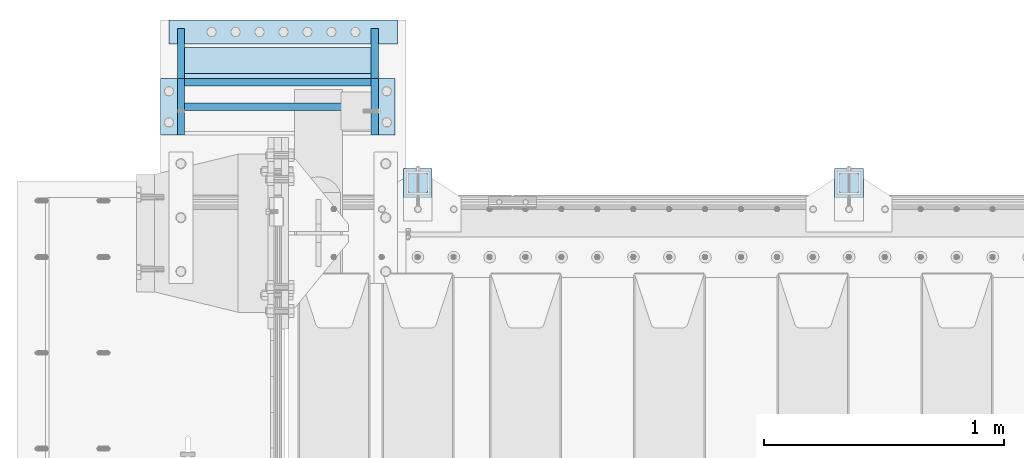
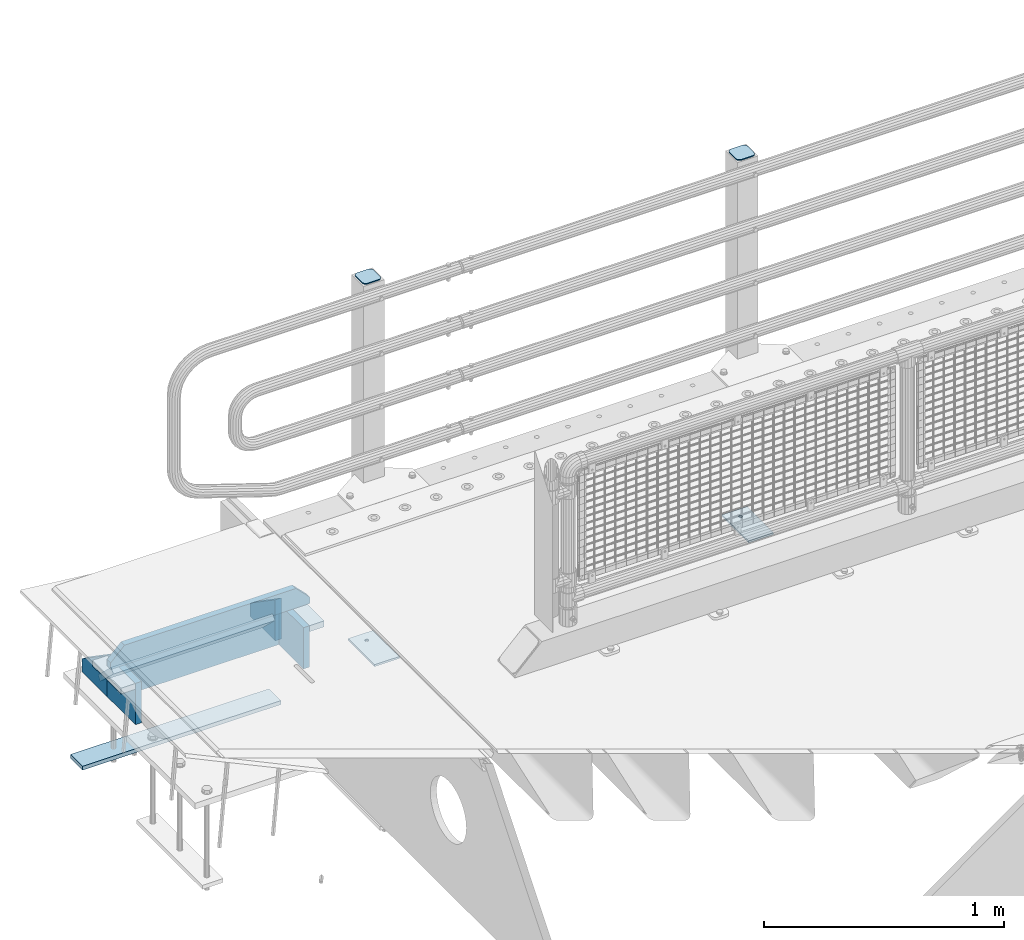
# One storey, part 231 of 270: 14 plates.
"""IFC2X3 building model written with IfcOpenShell, lengths in millimetres."""

from ifc_helpers import new_model, si_unit, frame, origin_with_axes, place, context, subcontext, project, spatial, faceted_brep, material, type_object, element, save


model = new_model("IFC2X3")

# Units and contexts
model_context = context("Model", 3, precision=1e-05, world=origin_with_axes())
body_context = subcontext(model_context, "Body", "Model", "MODEL_VIEW")
ifc_project = project(units=[si_unit("LENGTHUNIT", "METRE", prefix="MILLI"), si_unit("AREAUNIT", "SQUARE_METRE"), si_unit("VOLUMEUNIT", "CUBIC_METRE"), si_unit("MASSUNIT", "GRAM", prefix="KILO"), si_unit("TIMEUNIT", "SECOND"), si_unit("PLANEANGLEUNIT", "RADIAN"), si_unit("SOLIDANGLEUNIT", "STERADIAN"), si_unit("THERMODYNAMICTEMPERATUREUNIT", "DEGREE_CELSIUS"), si_unit("LUMINOUSINTENSITYUNIT", "LUMEN")], contexts=[model_context])

# Site, building, storey
site_placement = place(None, origin_with_axes())
site = spatial("IfcSite", under=ifc_project, at=site_placement, CompositionType="ELEMENT")
building_placement = place(site_placement, origin_with_axes())
building = spatial("IfcBuilding", under=site, at=building_placement, Name="Standard", CompositionType="ELEMENT")
storey_placement = place(building_placement, origin_with_axes())
storey = spatial("IfcBuildingStorey", under=building, at=storey_placement, Name="Undefined", CompositionType="ELEMENT", Elevation=0.0)

# Plates
ifc_material_1 = material(Name="STEEL/S355N")
plate_type_1 = type_object("IfcPlateType", PredefinedType="NOTDEFINED")
plate_1_placement = place(storey_placement, frame((354.999999574469, -14234.6428636522, -1027.14966545659), z_axis=(-1.0, 0.0, 0.0), x_axis=(9.99999918650255e-10, -0.723355636225728, 0.690475650215467)))
element("IfcPlate", 1, at=plate_1_placement, inside=storey, type_object=plate_type_1, material=ifc_material_1, context=body_context, shape_type="Brep", body=[
    faceted_brep([(0.0, -15.0, 0.0), (2.15506588574499e-07, -15.0000000000018, 779.0), (2.15506588574499e-07, 14.9999999999982, 779.0), (0.0, 15.0, 0.0), (152.069061494802, -15.0000000000018, 779.0), (152.069061494802, 14.9999999999982, 779.0), (152.069061279297, -15.0000000000018, 0.0), (152.069061279299, 14.9999999999964, 0.0)], [[[0, 1, 2, 3]], [[1, 4, 5, 2]], [[4, 6, 7, 5]], [[6, 0, 3, 7]], [[5, 7, 3, 2]], [[6, 4, 1, 0]]]),
])
plate_type_2 = type_object("IfcPlateType", PredefinedType="NOTDEFINED")
plate_2_placement = place(storey_placement, frame((-489.000000550228, -14110.0000007156, -1478.0), z_axis=(0.0, -1.0, 0.0), x_axis=(1.0, 0.0, 0.0)))
element("IfcPlate", 2, at=plate_2_placement, inside=storey, type_object=plate_type_2, material=ifc_material_1, context=body_context, shape_type="Brep", body=[
    faceted_brep([(0.0, -10.0, 0.0), (0.0, -10.0, 100.0), (0.0, 10.0, 100.0), (0.0, 10.0, 0.0), (955.0, -10.0, 100.0), (955.0, 10.0, 100.0), (955.0, -10.0, 0.0), (955.0, 10.0, 0.0)], [[[0, 1, 2, 3]], [[1, 4, 5, 2]], [[4, 6, 7, 5]], [[6, 0, 3, 7]], [[5, 7, 3, 2]], [[6, 4, 1, 0]]]),
])
plate_type_3 = type_object("IfcPlateType", PredefinedType="NOTDEFINED")
for number, where, z_axis, x_axis in (
    (3, (369.999999484789, -14144.9999983904, -1038.0), (0.0, 0.0, 1.0), (0.0, -1.0, 0.0)),
    (4, (-439.000000515214, -14144.9999991994, -1038.0), (0.0, 0.0, 1.0), (0.0, -1.0, 0.0)),
):
    element("IfcPlate", number, at=place(storey_placement, frame(where, z_axis=z_axis, x_axis=x_axis)), inside=storey, type_object=plate_type_3, material=ifc_material_1, context=body_context, shape_type="Brep", body=[
        faceted_brep([(0.0, -15.0, 0.0), (-1.81898940354586e-12, -15.0, 66.0), (0.0, 15.0, 66.0), (0.0, 15.0, 0.0), (209.999999999998, -15.0, 210.0), (210.0, 15.0, 210.0), (209.999999999998, -15.0, 0.0), (210.0, 15.0, 0.0)], [[[0, 1, 2, 3]], [[1, 4, 5, 2]], [[4, 6, 7, 5]], [[6, 0, 3, 7]], [[5, 7, 3, 2]], [[6, 4, 1, 0]]]),
    ])
plate_3_placement = place(storey_placement, frame((369.999999929987, -14589.9999983904, -828.000000000005), z_axis=(0.0, 0.0, -1.0), x_axis=(0.0, 1.0, 0.0)))
element("IfcPlate", 5, at=plate_3_placement, inside=storey, type_object=plate_type_3, material=ifc_material_1, context=body_context, shape_type="Brep", body=[
    faceted_brep([(0.0, -15.0, 0.0), (1.81898940354586e-12, -15.0, 210.0), (0.0, 15.0, 210.0), (0.0, 15.0, 0.0), (235.000000000002, -15.0, 210.0), (235.0, 15.0, 210.0), (235.0, -15.0, 0.0), (235.0, 15.0, 0.0)], [[[0, 1, 2, 3]], [[1, 4, 5, 2]], [[4, 6, 7, 5]], [[6, 0, 3, 7]], [[5, 7, 3, 2]], [[6, 4, 1, 0]]]),
])
plate_4_placement = place(storey_placement, frame((-424.000000290111, -14369.9999991844, -1038.0), z_axis=(1.0, 0.0, 0.0), x_axis=(0.0, 0.0, 1.0)))
element("IfcPlate", 6, at=plate_4_placement, inside=storey, type_object=plate_type_3, material=ifc_material_1, context=body_context, shape_type="Brep", body=[
    faceted_brep([(0.0, -15.0, 0.0), (2.15506588574499e-07, -15.0000000000018, 779.0), (2.15506588574499e-07, 14.9999999999982, 779.0), (0.0, 15.0, 0.0), (210.0, -15.0, 779.0), (210.0, 15.0, 779.0), (209.999999999998, -15.0, 0.0), (210.0, 15.0, 0.0)], [[[0, 1, 2, 3]], [[1, 4, 5, 2]], [[4, 6, 7, 5]], [[6, 0, 3, 7]], [[5, 7, 3, 2]], [[6, 4, 1, 0]]]),
])
plate_5_placement = place(storey_placement, frame((-439.000000070013, -14589.9999991994, -828.000000000004), z_axis=(0.0, 0.0, -1.0), x_axis=(0.0, 1.0, 0.0)))
element("IfcPlate", 7, at=plate_5_placement, inside=storey, type_object=plate_type_3, material=ifc_material_1, context=body_context, shape_type="Brep", body=[
    faceted_brep([(0.0, -15.0, 0.0), (1.81898940354586e-12, -15.0, 210.0), (0.0, 15.0, 210.0), (0.0, 15.0, 0.0), (235.000000000002, -15.0, 210.0), (235.0, 15.0, 210.0), (235.0, -15.0, 0.0), (235.0, 15.0, 0.0)], [[[0, 1, 2, 3]], [[1, 4, 5, 2]], [[4, 6, 7, 5]], [[6, 0, 3, 7]], [[5, 7, 3, 2]], [[6, 4, 1, 0]]]),
])
plate_type_4 = type_object("IfcPlateType", PredefinedType="NOTDEFINED")
plate_6_placement = place(storey_placement, frame((-514.000000187565, -14472.4999992744, -798.000000000004), z_axis=(0.0, 0.0, 1.0), x_axis=(1.0, 0.0, 0.0)))
element("IfcPlate", 8, at=plate_6_placement, inside=storey, type_object=plate_type_4, material=ifc_material_1, context=body_context, shape_type="Brep", body=[
    faceted_brep([(0.0, -15.0, 0.0), (-1.13686837721616e-13, -15.0, 33.0), (0.0, 15.0, 33.0), (0.0, 15.0, 0.0), (66.9999999999999, -15.0, 100.0), (66.9999999999999, 15.0, 100.0), (892.0, -15.0000000000018, 100.0), (892.0, 14.9999999999982, 100.0), (959.0, -15.0, 33.0), (959.0, 15.0, 33.0), (959.0, -15.0, 0.0), (959.0, 15.0, 0.0)], [[[0, 1, 2, 3]], [[1, 4, 5, 2]], [[4, 6, 7, 5]], [[6, 8, 9, 7]], [[8, 10, 11, 9]], [[10, 0, 3, 11]], [[5, 7, 9, 11, 3, 2]], [[10, 8, 6, 4, 1, 0]]]),
])
plate_type_5 = type_object("IfcPlateType", PredefinedType="NOTDEFINED")
for number, where, z_axis, x_axis in (
    (9, (384.999999694883, -14354.9999983754, -843.000000000004), (1.0, 0.0, 0.0), (0.0, -1.0, 0.0)),
    (10, (-524.000000305117, -14354.9999992844, -843.000000000004), (1.0, 0.0, 0.0), (0.0, -1.0, 0.0)),
):
    element("IfcPlate", number, at=place(storey_placement, frame(where, z_axis=z_axis, x_axis=x_axis)), inside=storey, type_object=plate_type_5, material=ifc_material_1, context=body_context, shape_type="Brep", body=[
        faceted_brep([(0.0, -15.0, 0.0), (0.0, -15.0, 70.0), (0.0, 15.0, 70.0), (0.0, 15.0, 0.0), (235.0, -15.0, 70.0), (235.0, 15.0, 70.0), (235.0, -15.0, 0.0), (235.0, 15.0, 0.0)], [[[0, 1, 2, 3]], [[1, 4, 5, 2]], [[4, 6, 7, 5]], [[6, 0, 3, 7]], [[5, 7, 3, 2]], [[6, 4, 1, 0]]]),
    ])
ifc_material_2 = material(Name="STEEL/S355J2")
plate_type_6 = type_object("IfcPlateType", PredefinedType="NOTDEFINED")
for number, where, z_axis, x_axis in (
    (11, (2290.00000000014, -14949.9999999998, -850.000000000002), (0.0, 1.0, 0.0), (1.0, 0.0, 0.0)),
    (12, (490.000000000138, -14949.9999999998, -850.000000000002), (0.0, 1.0, 0.0), (1.0, 0.0, 0.0)),
):
    element("IfcPlate", number, at=place(storey_placement, frame(where, z_axis=z_axis, x_axis=x_axis)), inside=storey, type_object=plate_type_6, material=ifc_material_2, context=body_context, shape_type="Brep", body=[
        faceted_brep([(66.3639610305399, -5.0, 163.636038969114), (66.3639610305399, 5.0, 163.636038969114), (59.9999999998618, 5.0, 160.999999999793), (59.9999999998618, -5.0, 160.999999999793), (53.6360389691836, 5.0, 163.636038969114), (53.6360389691836, -5.0, 163.636038969114), (50.9999999998618, 5.0, 169.999999999793), (50.9999999998618, -5.0, 169.999999999793), (53.6360389691836, 5.0, 176.363961030471), (53.6360389691836, -5.0, 176.363961030471), (59.9999999998618, 5.0, 178.999999999793), (59.9999999998618, -5.0, 178.999999999793), (66.3639610305399, 5.0, 176.363961030471), (66.3639610305399, -5.0, 176.363961030471), (68.9999999998618, 5.0, 169.999999999793), (68.9999999998618, -5.0, 169.999999999793), (120.0, -5.0, 0.0), (120.0, -5.0, 220.0), (0.0, -5.0, 220.0), (0.0, -5.0, 0.0), (0.0, 5.0, 0.0), (120.0, 5.0, 0.0), (120.0, 5.0, 220.0), (0.0, 5.0, 220.0)], [[[0, 1, 2, 3]], [[3, 2, 4, 5]], [[5, 4, 6, 7]], [[7, 6, 8, 9]], [[9, 8, 10, 11]], [[11, 10, 12, 13]], [[13, 12, 14, 15]], [[15, 14, 1, 0]], [[16, 17, 18, 19], [3, 5, 7, 9, 11, 13, 15, 0]], [[16, 19, 20, 21]], [[17, 16, 21, 22]], [[18, 17, 22, 23]], [[19, 18, 23, 20]], [[22, 21, 20, 23], [10, 8, 6, 4, 2, 1, 14, 12]]]),
    ])
plate_type_7 = type_object("IfcPlateType", PredefinedType="NOTDEFINED")
plate_7_placement = place(storey_placement, frame((2394.00000000013, -14833.9999999998, 1012.50000000001), z_axis=(0.0, 1.0, 0.0), x_axis=(-1.0, 0.0, 0.0)))
element("IfcPlate", 13, at=plate_7_placement, inside=storey, type_object=plate_type_7, material=ifc_material_2, context=body_context, shape_type="Brep", body=[
    faceted_brep([(0.0, -2.5, 19.0), (0.0, -2.5, 69.0), (0.0, 2.5, 69.0), (0.0, 2.5, 19.0), (0.476369668544066, -2.5, 73.2278977451697), (0.476369668544066, 2.5, 73.2278977451697), (1.88159150985302, -2.5, 77.2437910432327), (1.88159150985302, 2.5, 77.2437910432327), (4.14520183310742, -2.5, 80.8463062353167), (4.14520183310742, 2.5, 80.8463062353167), (7.15369376468516, -2.5, 83.8547981668926), (7.15369376468516, 2.5, 83.8547981668926), (10.7562089567655, -2.5, 86.1184084901452), (10.7562089567655, 2.5, 86.1184084901452), (14.7721022548285, -2.5, 87.5236303314541), (14.7721022548285, 2.5, 87.5236303314541), (19.0, -2.5, 88.0), (19.0, 2.5, 88.0), (69.0, -2.5, 88.0), (69.0, 2.5, 88.0), (73.2278977451715, -2.5, 87.5236303314541), (73.2278977451715, 2.5, 87.5236303314541), (77.2437910432345, -2.5, 86.1184084901452), (77.2437910432345, 2.5, 86.1184084901452), (80.8463062353148, -2.5, 83.8547981668926), (80.8463062353148, 2.5, 83.8547981668926), (83.8547981668926, -2.5, 80.8463062353167), (83.8547981668926, 2.5, 80.8463062353167), (86.118408490147, -2.5, 77.2437910432345), (86.118408490147, 2.5, 77.2437910432345), (87.5236303314559, -2.5, 73.2278977451697), (87.5236303314559, 2.5, 73.2278977451697), (88.0, -2.5, 69.0), (88.0, 2.5, 69.0), (88.0, -2.5, 19.0), (88.0, 2.5, 19.0), (87.5236303314559, -2.5, 14.7721022548303), (87.5236303314559, 2.5, 14.7721022548303), (86.118408490147, -2.5, 10.7562089567673), (86.118408490147, 2.5, 10.7562089567673), (83.8547981668926, -2.5, 7.15369376468334), (83.8547981668926, 2.5, 7.15369376468334), (80.8463062353148, -2.5, 4.14520183310742), (80.8463062353148, 2.5, 4.14520183310742), (77.2437910432345, -2.5, 1.88159150985484), (77.2437910432345, 2.5, 1.88159150985484), (73.2278977451715, -2.5, 0.476369668545885), (73.2278977451715, 2.5, 0.476369668545885), (69.0, -2.5, 0.0), (69.0, 2.5, 0.0), (19.0, -2.5, 0.0), (19.0, 2.5, 0.0), (14.7721022548285, -2.5, 0.476369668545885), (14.7721022548285, 2.5, 0.476369668545885), (10.7562089567655, -2.5, 1.88159150985484), (10.7562089567655, 2.5, 1.88159150985484), (7.15369376468516, -2.5, 4.14520183310742), (7.15369376468516, 2.5, 4.14520183310742), (4.14520183310742, -2.5, 7.15369376468334), (4.14520183310742, 2.5, 7.15369376468334), (1.88159150985302, -2.5, 10.7562089567673), (1.88159150985302, 2.5, 10.7562089567673), (0.476369668544066, -2.5, 14.7721022548303), (0.476369668544066, 2.5, 14.7721022548303)], [[[0, 1, 2, 3]], [[1, 4, 5, 2]], [[4, 6, 7, 5]], [[6, 8, 9, 7]], [[8, 10, 11, 9]], [[10, 12, 13, 11]], [[12, 14, 15, 13]], [[14, 16, 17, 15]], [[16, 18, 19, 17]], [[18, 20, 21, 19]], [[20, 22, 23, 21]], [[22, 24, 25, 23]], [[24, 26, 27, 25]], [[26, 28, 29, 27]], [[28, 30, 31, 29]], [[30, 32, 33, 31]], [[32, 34, 35, 33]], [[34, 36, 37, 35]], [[36, 38, 39, 37]], [[38, 40, 41, 39]], [[40, 42, 43, 41]], [[42, 44, 45, 43]], [[44, 46, 47, 45]], [[46, 48, 49, 47]], [[48, 50, 51, 49]], [[50, 52, 53, 51]], [[52, 54, 55, 53]], [[54, 56, 57, 55]], [[56, 58, 59, 57]], [[58, 60, 61, 59]], [[60, 62, 63, 61]], [[62, 0, 3, 63]], [[5, 7, 9, 11, 13, 15, 17, 19, 21, 23, 25, 27, 29, 31, 33, 35, 37, 39, 41, 43, 45, 47, 49, 51, 53, 55, 57, 59, 61, 63, 3, 2]], [[62, 60, 58, 56, 54, 52, 50, 48, 46, 44, 42, 40, 38, 36, 34, 32, 30, 28, 26, 24, 22, 20, 18, 16, 14, 12, 10, 8, 6, 4, 1, 0]]]),
])
plate_8_placement = place(storey_placement, frame((594.000000000131, -14833.9999999998, 1012.50000000001), z_axis=(0.0, 1.0, 0.0), x_axis=(-1.0, 0.0, 0.0)))
element("IfcPlate", 14, at=plate_8_placement, inside=storey, type_object=plate_type_7, material=ifc_material_2, context=body_context, shape_type="Brep", body=[
    faceted_brep([(0.0, -2.5, 19.0), (0.0, -2.5, 69.0), (0.0, 2.5, 69.0), (0.0, 2.5, 19.0), (0.476369668544066, -2.5, 73.2278977451697), (0.476369668544066, 2.5, 73.2278977451697), (1.88159150985302, -2.5, 77.2437910432327), (1.88159150985302, 2.5, 77.2437910432327), (4.14520183310742, -2.5, 80.8463062353167), (4.14520183310742, 2.5, 80.8463062353167), (7.15369376468516, -2.5, 83.8547981668926), (7.15369376468516, 2.5, 83.8547981668926), (10.7562089567655, -2.5, 86.1184084901452), (10.7562089567655, 2.5, 86.1184084901452), (14.7721022548285, -2.5, 87.5236303314541), (14.7721022548285, 2.5, 87.5236303314541), (19.0, -2.5, 88.0), (19.0, 2.5, 88.0), (69.0, -2.5, 88.0), (69.0, 2.5, 88.0), (73.2278977451715, -2.5, 87.5236303314541), (73.2278977451715, 2.5, 87.5236303314541), (77.2437910432345, -2.5, 86.1184084901452), (77.2437910432345, 2.5, 86.1184084901452), (80.8463062353148, -2.5, 83.8547981668926), (80.8463062353148, 2.5, 83.8547981668926), (83.8547981668926, -2.5, 80.8463062353167), (83.8547981668926, 2.5, 80.8463062353167), (86.118408490147, -2.5, 77.2437910432345), (86.118408490147, 2.5, 77.2437910432345), (87.5236303314559, -2.5, 73.2278977451697), (87.5236303314559, 2.5, 73.2278977451697), (88.0, -2.5, 69.0), (88.0, 2.5, 69.0), (88.0, -2.5, 19.0), (88.0, 2.5, 19.0), (87.5236303314559, -2.5, 14.7721022548303), (87.5236303314559, 2.5, 14.7721022548303), (86.118408490147, -2.5, 10.7562089567673), (86.118408490147, 2.5, 10.7562089567673), (83.8547981668926, -2.5, 7.15369376468334), (83.8547981668926, 2.5, 7.15369376468334), (80.8463062353148, -2.5, 4.14520183310742), (80.8463062353148, 2.5, 4.14520183310742), (77.2437910432345, -2.5, 1.88159150985484), (77.2437910432345, 2.5, 1.88159150985484), (73.2278977451715, -2.5, 0.476369668545885), (73.2278977451715, 2.5, 0.476369668545885), (69.0, -2.5, 0.0), (69.0, 2.5, 0.0), (19.0, -2.5, 0.0), (19.0, 2.5, 0.0), (14.7721022548285, -2.5, 0.476369668545885), (14.7721022548285, 2.5, 0.476369668545885), (10.7562089567655, -2.5, 1.88159150985484), (10.7562089567655, 2.5, 1.88159150985484), (7.15369376468516, -2.5, 4.14520183310742), (7.15369376468516, 2.5, 4.14520183310742), (4.14520183310742, -2.5, 7.15369376468334), (4.14520183310742, 2.5, 7.15369376468334), (1.88159150985302, -2.5, 10.7562089567673), (1.88159150985302, 2.5, 10.7562089567673), (0.476369668544066, -2.5, 14.7721022548303), (0.476369668544066, 2.5, 14.7721022548303)], [[[0, 1, 2, 3]], [[1, 4, 5, 2]], [[4, 6, 7, 5]], [[6, 8, 9, 7]], [[8, 10, 11, 9]], [[10, 12, 13, 11]], [[12, 14, 15, 13]], [[14, 16, 17, 15]], [[16, 18, 19, 17]], [[18, 20, 21, 19]], [[20, 22, 23, 21]], [[22, 24, 25, 23]], [[24, 26, 27, 25]], [[26, 28, 29, 27]], [[28, 30, 31, 29]], [[30, 32, 33, 31]], [[32, 34, 35, 33]], [[34, 36, 37, 35]], [[36, 38, 39, 37]], [[38, 40, 41, 39]], [[40, 42, 43, 41]], [[42, 44, 45, 43]], [[44, 46, 47, 45]], [[46, 48, 49, 47]], [[48, 50, 51, 49]], [[50, 52, 53, 51]], [[52, 54, 55, 53]], [[54, 56, 57, 55]], [[56, 58, 59, 57]], [[58, 60, 61, 59]], [[60, 62, 63, 61]], [[62, 0, 3, 63]], [[5, 7, 9, 11, 13, 15, 17, 19, 21, 23, 25, 27, 29, 31, 33, 35, 37, 39, 41, 43, 45, 47, 49, 51, 53, 55, 57, 59, 61, 63, 3, 2]], [[62, 60, 58, 56, 54, 52, 50, 48, 46, 44, 42, 40, 38, 36, 34, 32, 30, 28, 26, 24, 22, 20, 18, 16, 14, 12, 10, 8, 6, 4, 1, 0]]]),
])

save(model, "model.ifc")
